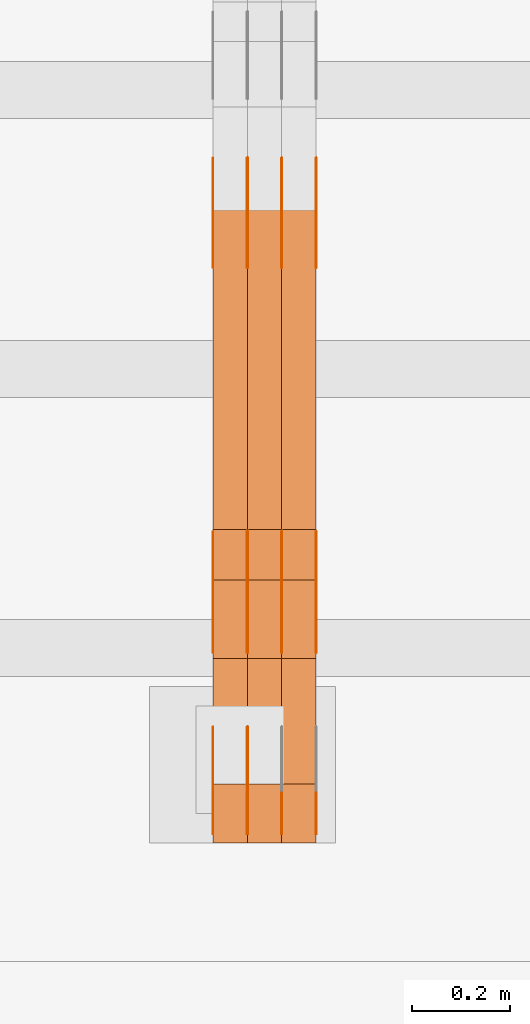
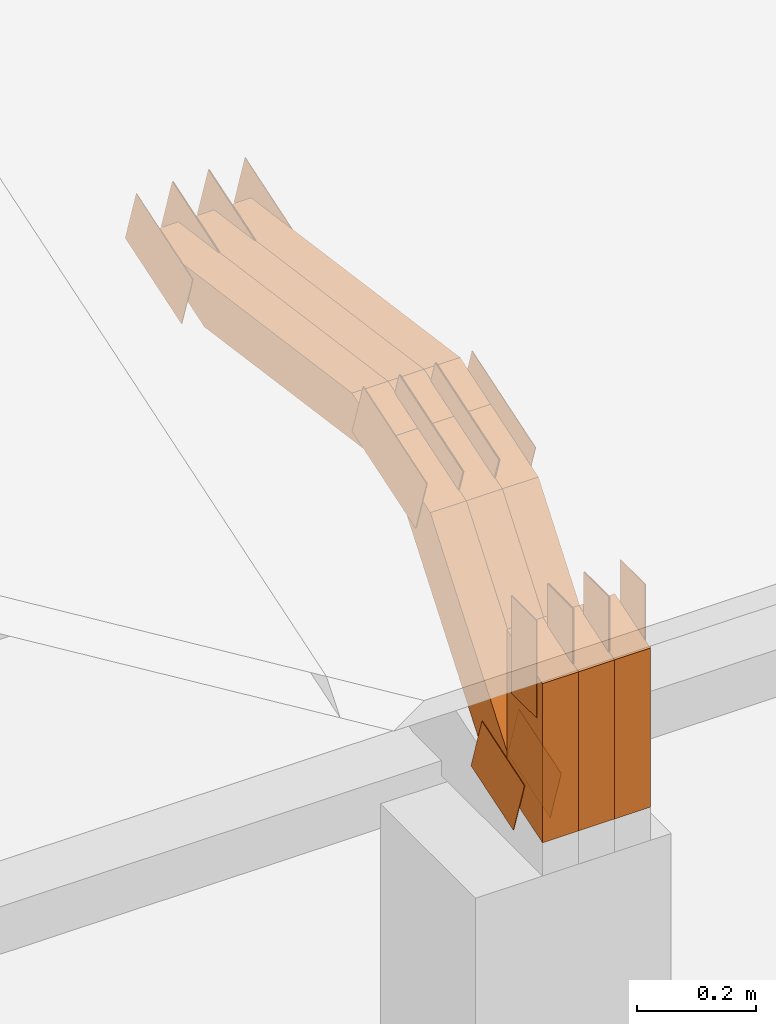
# One storey, part 267 of 385: 29 proxies.
"""IFC2X3 building model written with IfcOpenShell, lengths in millimetres."""

from ifc_helpers import new_model, entity, si_unit, converted_unit, derived_unit, direction, frame, frame_2d, origin, place, context, subcontext, project, spatial, polyline, rectangle, outline, extrude, source, transform, mapped, material, type_object, type_shapes, element, save


model = new_model("IFC2X3")

# Units and contexts
model_context = context("Model", 3, precision=0.01, world=origin(), true_north=direction((6.12303176911189e-17, 1.0)))
body_context = subcontext(model_context, "Body", "Model", "MODEL_VIEW")
ifc_project = project(units=[si_unit("LENGTHUNIT", "METRE", prefix="MILLI"), si_unit("AREAUNIT", "SQUARE_METRE"), si_unit("VOLUMEUNIT", "CUBIC_METRE"), converted_unit("PLANEANGLEUNIT", "DEGREE", entity("IfcRatioMeasure", 0.0174532925199433), si_unit("PLANEANGLEUNIT", "RADIAN"), dimensions=[0, 0, 0, 0, 0, 0, 0]), si_unit("MASSUNIT", "GRAM", prefix="KILO"), derived_unit("MASSDENSITYUNIT", [(si_unit("MASSUNIT", "GRAM", prefix="KILO"), 1), (si_unit("LENGTHUNIT", "METRE"), -3)]), si_unit("TIMEUNIT", "SECOND"), si_unit("FREQUENCYUNIT", "HERTZ"), si_unit("THERMODYNAMICTEMPERATUREUNIT", "DEGREE_CELSIUS"), derived_unit("THERMALTRANSMITTANCEUNIT", [(si_unit("MASSUNIT", "GRAM", prefix="KILO"), 1), (si_unit("THERMODYNAMICTEMPERATUREUNIT", "KELVIN"), -1), (si_unit("TIMEUNIT", "SECOND"), -3)]), derived_unit("VOLUMETRICFLOWRATEUNIT", [(si_unit("LENGTHUNIT", "METRE"), 3), (si_unit("TIMEUNIT", "SECOND"), -1)]), si_unit("ELECTRICCURRENTUNIT", "AMPERE"), si_unit("ELECTRICVOLTAGEUNIT", "VOLT"), si_unit("POWERUNIT", "WATT"), si_unit("FORCEUNIT", "NEWTON", prefix="KILO"), si_unit("ILLUMINANCEUNIT", "LUX"), si_unit("LUMINOUSFLUXUNIT", "LUMEN"), si_unit("LUMINOUSINTENSITYUNIT", "CANDELA"), derived_unit("USERDEFINED", [(si_unit("MASSUNIT", "GRAM", prefix="KILO"), -1), (si_unit("LENGTHUNIT", "METRE"), -2), (si_unit("TIMEUNIT", "SECOND"), 3), (si_unit("LUMINOUSFLUXUNIT", "LUMEN"), 1)]), derived_unit("LINEARVELOCITYUNIT", [(si_unit("LENGTHUNIT", "METRE"), 1), (si_unit("TIMEUNIT", "SECOND"), -1)]), si_unit("PRESSUREUNIT", "PASCAL"), derived_unit("USERDEFINED", [(si_unit("LENGTHUNIT", "METRE"), -2), (si_unit("MASSUNIT", "GRAM", prefix="KILO"), 1), (si_unit("TIMEUNIT", "SECOND"), -2)])], contexts=[model_context])

# Site, building, storey
site_placement = place(None, origin())
site = spatial("IfcSite", under=ifc_project, at=site_placement, CompositionType="ELEMENT")
building_placement = place(site_placement, origin())
building = spatial("IfcBuilding", under=site, at=building_placement, CompositionType="ELEMENT")
storey_placement = place(building_placement, origin())
storey = spatial("IfcBuildingStorey", under=building, at=storey_placement, Name="Default", CompositionType="ELEMENT", Elevation=0.0)

# Proxies
ifc_material_1 = material(Name="IfcSurfaceStyle #546392")
building_element_proxy_type_1 = type_object("IfcBuildingElementProxyType", PredefinedType="NOTDEFINED", material=ifc_material_1)
shared_shape_1 = source(origin(), body_context, "Body", "SweptSolid", [
    extrude(outline(polyline([(-74.999865408764, -60.0000379172698), (74.9998729365771, -60.0000379172698), (74.9998642299588, 60.0000379172698), (-74.9998717577719, 60.0000379172698), (-74.999865408764, -60.0000379172698)])), frame((75.0005044383734, 60.0001679035349, 0.0), z_axis=(0.0, 0.0, 1.0), x_axis=(-1.0, 0.0, 0.0)), (0.0, 0.0, 1.0), 1.29999999999999),
])
type_shapes(building_element_proxy_type_1, [shared_shape_1])
proxy_1_placement = place(building_placement, frame((45246.3, 2998.66143710398, 150.423871180894), z_axis=(-1.0, 0.0, 0.0), x_axis=(0.0, 0.951056516295124, 0.309016994375039)))
element("IfcBuildingElementProxy", 1, at=proxy_1_placement, inside=storey, type_object=building_element_proxy_type_1, material=ifc_material_1, context=body_context, shape_type="MappedRepresentation", body=[
    mapped(shared_shape_1, transform((0.0, 0.0, 0.0), scale=1.0)),
])
ifc_material_2 = material(Name="IfcSurfaceStyle #546335")
building_element_proxy_type_2 = type_object("IfcBuildingElementProxyType", PredefinedType="NOTDEFINED", material=ifc_material_2)
shared_shape_2 = source(origin(), body_context, "Body", "SweptSolid", [
    extrude(outline(polyline([(-74.999865408764, -60.0000379172698), (74.9998729365771, -60.0000379172698), (74.9998642299588, 60.0000379172698), (-74.9998717577719, 60.0000379172698), (-74.999865408764, -60.0000379172698)])), frame((75.0005044383734, 60.0001679035349, 0.0), z_axis=(0.0, 0.0, 1.0), x_axis=(-1.0, 0.0, 0.0)), (0.0, 0.0, 1.0), 1.29999999999999),
])
type_shapes(building_element_proxy_type_2, [shared_shape_2])
proxy_2_placement = place(building_placement, frame((45175.0, 2998.66143710398, 150.423871180894), z_axis=(-1.0, 0.0, 0.0), x_axis=(0.0, 0.951056516295124, 0.309016994375039)))
element("IfcBuildingElementProxy", 2, at=proxy_2_placement, inside=storey, type_object=building_element_proxy_type_2, material=ifc_material_2, context=body_context, shape_type="MappedRepresentation", body=[
    mapped(shared_shape_2, transform((0.0, 0.0, 0.0), scale=1.0)),
])
ifc_material_3 = material(Name="IfcSurfaceStyle #546278")
building_element_proxy_type_3 = type_object("IfcBuildingElementProxyType", PredefinedType="NOTDEFINED", material=ifc_material_3)
shared_shape_3 = source(origin(), body_context, "Body", "SweptSolid", [
    extrude(outline(polyline([(-99.9998204243802, -60.000067376167), (99.9998338462265, -60.000067376167), (99.9998204243802, 60.000067376167), (-99.9998338462265, 60.000067376167), (-99.9998204243802, -60.000067376167)])), frame((100.000602015329, 60.0001864986889, 0.0), z_axis=(0.0, 0.0, 1.0), x_axis=(-1.0, 0.0, 0.0)), (0.0, 0.0, 1.0), 1.3),
])
type_shapes(building_element_proxy_type_3, [shared_shape_3])
proxy_3_placement = place(building_placement, frame((45386.3, 4114.85465165113, 513.097031388771), z_axis=(-1.0, 0.0, 0.0), x_axis=(0.0, 0.951056516295124, 0.309016994375039)))
element("IfcBuildingElementProxy", 3, at=proxy_3_placement, inside=storey, type_object=building_element_proxy_type_3, material=ifc_material_3, context=body_context, shape_type="MappedRepresentation", body=[
    mapped(shared_shape_3, transform((0.0, 0.0, 0.0), scale=1.0)),
])
ifc_material_4 = material(Name="IfcSurfaceStyle #546221")
building_element_proxy_type_4 = type_object("IfcBuildingElementProxyType", PredefinedType="NOTDEFINED", material=ifc_material_4)
shared_shape_4 = source(origin(), body_context, "Body", "SweptSolid", [
    extrude(outline(polyline([(-99.9998204243802, -60.000067376167), (99.9998338462265, -60.000067376167), (99.9998204243802, 60.000067376167), (-99.9998338462265, 60.000067376167), (-99.9998204243802, -60.000067376167)])), frame((100.000602015329, 60.0001864986889, 0.0), z_axis=(0.0, 0.0, 1.0), x_axis=(-1.0, 0.0, 0.0)), (0.0, 0.0, 1.0), 1.3),
])
type_shapes(building_element_proxy_type_4, [shared_shape_4])
proxy_4_placement = place(building_placement, frame((45315.0, 4114.85465165113, 513.097031388771), z_axis=(-1.0, 0.0, 0.0), x_axis=(0.0, 0.951056516295124, 0.309016994375039)))
element("IfcBuildingElementProxy", 4, at=proxy_4_placement, inside=storey, type_object=building_element_proxy_type_4, material=ifc_material_4, context=body_context, shape_type="MappedRepresentation", body=[
    mapped(shared_shape_4, transform((0.0, 0.0, 0.0), scale=1.0)),
])
ifc_material_5 = material(Name="IfcSurfaceStyle #546164")
building_element_proxy_type_5 = type_object("IfcBuildingElementProxyType", PredefinedType="NOTDEFINED", material=ifc_material_5)
shared_shape_5 = source(origin(), body_context, "Body", "SweptSolid", [
    extrude(outline(polyline([(-99.9998204243802, -60.000067376167), (99.9998338462265, -60.000067376167), (99.9998204243802, 60.000067376167), (-99.9998338462265, 60.000067376167), (-99.9998204243802, -60.000067376167)])), frame((100.000602015329, 60.0001864986889, 0.0), z_axis=(0.0, 0.0, 1.0), x_axis=(-1.0, 0.0, 0.0)), (0.0, 0.0, 1.0), 1.3),
])
type_shapes(building_element_proxy_type_5, [shared_shape_5])
proxy_5_placement = place(building_placement, frame((45316.3, 4114.85465165113, 513.097031388771), z_axis=(-1.0, 0.0, 0.0), x_axis=(0.0, 0.951056516295124, 0.309016994375039)))
element("IfcBuildingElementProxy", 5, at=proxy_5_placement, inside=storey, type_object=building_element_proxy_type_5, material=ifc_material_5, context=body_context, shape_type="MappedRepresentation", body=[
    mapped(shared_shape_5, transform((0.0, 0.0, 0.0), scale=1.0)),
])
ifc_material_6 = material(Name="IfcSurfaceStyle #546107")
building_element_proxy_type_6 = type_object("IfcBuildingElementProxyType", PredefinedType="NOTDEFINED", material=ifc_material_6)
shared_shape_6 = source(origin(), body_context, "Body", "SweptSolid", [
    extrude(outline(polyline([(-99.9998204243802, -60.000067376167), (99.9998338462265, -60.000067376167), (99.9998204243802, 60.000067376167), (-99.9998338462265, 60.000067376167), (-99.9998204243802, -60.000067376167)])), frame((100.000602015329, 60.0001864986889, 0.0), z_axis=(0.0, 0.0, 1.0), x_axis=(-1.0, 0.0, 0.0)), (0.0, 0.0, 1.0), 1.29999999999998),
])
type_shapes(building_element_proxy_type_6, [shared_shape_6])
proxy_6_placement = place(building_placement, frame((45245.0, 4114.85465165113, 513.097031388771), z_axis=(-1.0, 0.0, 0.0), x_axis=(0.0, 0.951056516295124, 0.309016994375039)))
element("IfcBuildingElementProxy", 6, at=proxy_6_placement, inside=storey, type_object=building_element_proxy_type_6, material=ifc_material_6, context=body_context, shape_type="MappedRepresentation", body=[
    mapped(shared_shape_6, transform((0.0, 0.0, 0.0), scale=1.0)),
])
ifc_material_7 = material(Name="IfcSurfaceStyle #546050")
building_element_proxy_type_7 = type_object("IfcBuildingElementProxyType", PredefinedType="NOTDEFINED", material=ifc_material_7)
shared_shape_7 = source(origin(), body_context, "Body", "SweptSolid", [
    extrude(outline(polyline([(-99.9998204243802, -60.000067376167), (99.9998338462265, -60.000067376167), (99.9998204243802, 60.000067376167), (-99.9998338462265, 60.000067376167), (-99.9998204243802, -60.000067376167)])), frame((100.000602015329, 60.0001864986889, 0.0), z_axis=(0.0, 0.0, 1.0), x_axis=(-1.0, 0.0, 0.0)), (0.0, 0.0, 1.0), 1.29999999999998),
])
type_shapes(building_element_proxy_type_7, [shared_shape_7])
proxy_7_placement = place(building_placement, frame((45246.3, 4114.85465165113, 513.097031388771), z_axis=(-1.0, 0.0, 0.0), x_axis=(0.0, 0.951056516295124, 0.309016994375039)))
element("IfcBuildingElementProxy", 7, at=proxy_7_placement, inside=storey, type_object=building_element_proxy_type_7, material=ifc_material_7, context=body_context, shape_type="MappedRepresentation", body=[
    mapped(shared_shape_7, transform((0.0, 0.0, 0.0), scale=1.0)),
])
ifc_material_8 = material(Name="IfcSurfaceStyle #545993")
building_element_proxy_type_8 = type_object("IfcBuildingElementProxyType", PredefinedType="NOTDEFINED", material=ifc_material_8)
shared_shape_8 = source(origin(), body_context, "Body", "SweptSolid", [
    extrude(outline(polyline([(-99.9998204243802, -60.000067376167), (99.9998338462265, -60.000067376167), (99.9998204243802, 60.000067376167), (-99.9998338462265, 60.000067376167), (-99.9998204243802, -60.000067376167)])), frame((100.000602015329, 60.0001864986889, 0.0), z_axis=(0.0, 0.0, 1.0), x_axis=(-1.0, 0.0, 0.0)), (0.0, 0.0, 1.0), 1.29999999999999),
])
type_shapes(building_element_proxy_type_8, [shared_shape_8])
proxy_8_placement = place(building_placement, frame((45175.0, 4114.85465165113, 513.097031388771), z_axis=(-1.0, 0.0, 0.0), x_axis=(0.0, 0.951056516295124, 0.309016994375039)))
element("IfcBuildingElementProxy", 8, at=proxy_8_placement, inside=storey, type_object=building_element_proxy_type_8, material=ifc_material_8, context=body_context, shape_type="MappedRepresentation", body=[
    mapped(shared_shape_8, transform((0.0, 0.0, 0.0), scale=1.0)),
])
ifc_material_9 = material(Name="IfcSurfaceStyle #538070")
building_element_proxy_type_9 = type_object("IfcBuildingElementProxyType", PredefinedType="NOTDEFINED", material=ifc_material_9)
shared_shape_9 = source(origin(), body_context, "Body", "SweptSolid", [
    extrude(outline(polyline([(-112.500266735783, -59.9999130784581), (112.500275442392, -59.9999130784581), (112.500262020557, 59.9999130784582), (-112.500270727166, 59.9999130784581), (-112.500266735783, -59.9999130784581)])), frame((112.500275442392, 60.0001020984692, 0.0), z_axis=(0.0, 0.0, 1.0), x_axis=(-1.0, 0.0, 0.0)), (0.0, 0.0, 1.0), 1.3),
])
type_shapes(building_element_proxy_type_9, [shared_shape_9])
proxy_9_placement = place(building_placement, frame((45386.3, 3327.32420598509, 571.284602786019), z_axis=(-1.0, 0.0, 0.0), x_axis=(0.0, 0.951056516295154, 0.309016994374948)))
element("IfcBuildingElementProxy", 9, at=proxy_9_placement, inside=storey, type_object=building_element_proxy_type_9, material=ifc_material_9, context=body_context, shape_type="MappedRepresentation", body=[
    mapped(shared_shape_9, transform((0.0, 0.0, 0.0), scale=1.0)),
])
ifc_material_10 = material(Name="IfcSurfaceStyle #538013")
building_element_proxy_type_10 = type_object("IfcBuildingElementProxyType", PredefinedType="NOTDEFINED", material=ifc_material_10)
shared_shape_10 = source(origin(), body_context, "Body", "SweptSolid", [
    extrude(outline(polyline([(-112.500266735783, -59.9999130784581), (112.500275442392, -59.9999130784581), (112.500262020557, 59.9999130784582), (-112.500270727166, 59.9999130784581), (-112.500266735783, -59.9999130784581)])), frame((112.500275442392, 60.0001020984692, 0.0), z_axis=(0.0, 0.0, 1.0), x_axis=(-1.0, 0.0, 0.0)), (0.0, 0.0, 1.0), 1.3),
])
type_shapes(building_element_proxy_type_10, [shared_shape_10])
proxy_10_placement = place(building_placement, frame((45315.0, 3327.32420598509, 571.284602786019), z_axis=(-1.0, 0.0, 0.0), x_axis=(0.0, 0.951056516295154, 0.309016994374948)))
element("IfcBuildingElementProxy", 10, at=proxy_10_placement, inside=storey, type_object=building_element_proxy_type_10, material=ifc_material_10, context=body_context, shape_type="MappedRepresentation", body=[
    mapped(shared_shape_10, transform((0.0, 0.0, 0.0), scale=1.0)),
])
ifc_material_11 = material(Name="IfcSurfaceStyle #537956")
building_element_proxy_type_11 = type_object("IfcBuildingElementProxyType", PredefinedType="NOTDEFINED", material=ifc_material_11)
shared_shape_11 = source(origin(), body_context, "Body", "SweptSolid", [
    extrude(outline(polyline([(-112.500266735783, -59.9999130784581), (112.500275442392, -59.9999130784581), (112.500262020557, 59.9999130784582), (-112.500270727166, 59.9999130784581), (-112.500266735783, -59.9999130784581)])), frame((112.500275442392, 60.0001020984692, 0.0), z_axis=(0.0, 0.0, 1.0), x_axis=(-1.0, 0.0, 0.0)), (0.0, 0.0, 1.0), 1.3),
])
type_shapes(building_element_proxy_type_11, [shared_shape_11])
proxy_11_placement = place(building_placement, frame((45316.3, 3327.32420598509, 571.284602786019), z_axis=(-1.0, 0.0, 0.0), x_axis=(0.0, 0.951056516295154, 0.309016994374948)))
element("IfcBuildingElementProxy", 11, at=proxy_11_placement, inside=storey, type_object=building_element_proxy_type_11, material=ifc_material_11, context=body_context, shape_type="MappedRepresentation", body=[
    mapped(shared_shape_11, transform((0.0, 0.0, 0.0), scale=1.0)),
])
ifc_material_12 = material(Name="IfcSurfaceStyle #537899")
building_element_proxy_type_12 = type_object("IfcBuildingElementProxyType", PredefinedType="NOTDEFINED", material=ifc_material_12)
shared_shape_12 = source(origin(), body_context, "Body", "SweptSolid", [
    extrude(outline(polyline([(-112.500266735783, -59.9999130784581), (112.500275442392, -59.9999130784581), (112.500262020557, 59.9999130784582), (-112.500270727166, 59.9999130784581), (-112.500266735783, -59.9999130784581)])), frame((112.500275442392, 60.0001020984692, 0.0), z_axis=(0.0, 0.0, 1.0), x_axis=(-1.0, 0.0, 0.0)), (0.0, 0.0, 1.0), 1.29999999999998),
])
type_shapes(building_element_proxy_type_12, [shared_shape_12])
proxy_12_placement = place(building_placement, frame((45245.0, 3327.32420598509, 571.284602786019), z_axis=(-1.0, 0.0, 0.0), x_axis=(0.0, 0.951056516295154, 0.309016994374948)))
element("IfcBuildingElementProxy", 12, at=proxy_12_placement, inside=storey, type_object=building_element_proxy_type_12, material=ifc_material_12, context=body_context, shape_type="MappedRepresentation", body=[
    mapped(shared_shape_12, transform((0.0, 0.0, 0.0), scale=1.0)),
])
ifc_material_13 = material(Name="IfcSurfaceStyle #537842")
building_element_proxy_type_13 = type_object("IfcBuildingElementProxyType", PredefinedType="NOTDEFINED", material=ifc_material_13)
shared_shape_13 = source(origin(), body_context, "Body", "SweptSolid", [
    extrude(outline(polyline([(-112.500266735783, -59.9999130784581), (112.500275442392, -59.9999130784581), (112.500262020557, 59.9999130784582), (-112.500270727166, 59.9999130784581), (-112.500266735783, -59.9999130784581)])), frame((112.500275442392, 60.0001020984692, 0.0), z_axis=(0.0, 0.0, 1.0), x_axis=(-1.0, 0.0, 0.0)), (0.0, 0.0, 1.0), 1.29999999999998),
])
type_shapes(building_element_proxy_type_13, [shared_shape_13])
proxy_13_placement = place(building_placement, frame((45246.3, 3327.32420598509, 571.284602786019), z_axis=(-1.0, 0.0, 0.0), x_axis=(0.0, 0.951056516295154, 0.309016994374948)))
element("IfcBuildingElementProxy", 13, at=proxy_13_placement, inside=storey, type_object=building_element_proxy_type_13, material=ifc_material_13, context=body_context, shape_type="MappedRepresentation", body=[
    mapped(shared_shape_13, transform((0.0, 0.0, 0.0), scale=1.0)),
])
ifc_material_14 = material(Name="IfcSurfaceStyle #537785")
building_element_proxy_type_14 = type_object("IfcBuildingElementProxyType", PredefinedType="NOTDEFINED", material=ifc_material_14)
shared_shape_14 = source(origin(), body_context, "Body", "SweptSolid", [
    extrude(outline(polyline([(-112.500266735783, -59.9999130784581), (112.500275442392, -59.9999130784581), (112.500262020557, 59.9999130784582), (-112.500270727166, 59.9999130784581), (-112.500266735783, -59.9999130784581)])), frame((112.500275442392, 60.0001020984692, 0.0), z_axis=(0.0, 0.0, 1.0), x_axis=(-1.0, 0.0, 0.0)), (0.0, 0.0, 1.0), 1.29999999999999),
])
type_shapes(building_element_proxy_type_14, [shared_shape_14])
proxy_14_placement = place(building_placement, frame((45175.0, 3327.32420598509, 571.284602786019), z_axis=(-1.0, 0.0, 0.0), x_axis=(0.0, 0.951056516295154, 0.309016994374948)))
element("IfcBuildingElementProxy", 14, at=proxy_14_placement, inside=storey, type_object=building_element_proxy_type_14, material=ifc_material_14, context=body_context, shape_type="MappedRepresentation", body=[
    mapped(shared_shape_14, transform((0.0, 0.0, 0.0), scale=1.0)),
])
ifc_material_15 = material(Name="IfcSurfaceStyle #537044")
building_element_proxy_type_15 = type_object("IfcBuildingElementProxyType", PredefinedType="NOTDEFINED", material=ifc_material_15)
shared_shape_15 = source(origin(), body_context, "Body", "SweptSolid", [
    extrude(rectangle(XDim=199.999969482422, YDim=84.0, at=frame_2d((1.4210854715202e-14, 0.0), x_axis=(1.0, 0.0))), frame((100.000010815955, 42.0, 0.0), z_axis=(0.0, 0.0, 1.0), x_axis=(-1.0, 0.0, 0.0)), (0.0, 0.0, 1.0), 1.3),
])
type_shapes(building_element_proxy_type_15, [shared_shape_15])
proxy_15_placement = place(building_placement, frame((45386.3, 3042.0, 514.460048047401), z_axis=(-1.0, 0.0, 0.0), x_axis=(0.0, 0.0, -1.0)))
element("IfcBuildingElementProxy", 15, at=proxy_15_placement, inside=storey, type_object=building_element_proxy_type_15, material=ifc_material_15, context=body_context, shape_type="MappedRepresentation", body=[
    mapped(shared_shape_15, transform((0.0, 0.0, 0.0), scale=1.0)),
])
ifc_material_16 = material(Name="IfcSurfaceStyle #536987")
building_element_proxy_type_16 = type_object("IfcBuildingElementProxyType", PredefinedType="NOTDEFINED", material=ifc_material_16)
shared_shape_16 = source(origin(), body_context, "Body", "SweptSolid", [
    extrude(rectangle(XDim=199.999969482422, YDim=84.0, at=frame_2d((1.4210854715202e-14, 0.0), x_axis=(1.0, 0.0))), frame((100.000010815955, 42.0, 0.0), z_axis=(0.0, 0.0, 1.0), x_axis=(-1.0, 0.0, 0.0)), (0.0, 0.0, 1.0), 1.3),
])
type_shapes(building_element_proxy_type_16, [shared_shape_16])
proxy_16_placement = place(building_placement, frame((45315.0, 3042.0, 514.460048047401), z_axis=(-1.0, 0.0, 0.0), x_axis=(0.0, 0.0, -1.0)))
element("IfcBuildingElementProxy", 16, at=proxy_16_placement, inside=storey, type_object=building_element_proxy_type_16, material=ifc_material_16, context=body_context, shape_type="MappedRepresentation", body=[
    mapped(shared_shape_16, transform((0.0, 0.0, 0.0), scale=1.0)),
])
ifc_material_17 = material(Name="IfcSurfaceStyle #536930")
building_element_proxy_type_17 = type_object("IfcBuildingElementProxyType", PredefinedType="NOTDEFINED", material=ifc_material_17)
shared_shape_17 = source(origin(), body_context, "Body", "SweptSolid", [
    extrude(rectangle(XDim=199.999969482422, YDim=84.0, at=frame_2d((1.4210854715202e-14, 0.0), x_axis=(1.0, 0.0))), frame((100.000010815955, 42.0, 0.0), z_axis=(0.0, 0.0, 1.0), x_axis=(-1.0, 0.0, 0.0)), (0.0, 0.0, 1.0), 1.3),
])
type_shapes(building_element_proxy_type_17, [shared_shape_17])
proxy_17_placement = place(building_placement, frame((45316.3, 3042.0, 514.460048047401), z_axis=(-1.0, 0.0, 0.0), x_axis=(0.0, 0.0, -1.0)))
element("IfcBuildingElementProxy", 17, at=proxy_17_placement, inside=storey, type_object=building_element_proxy_type_17, material=ifc_material_17, context=body_context, shape_type="MappedRepresentation", body=[
    mapped(shared_shape_17, transform((0.0, 0.0, 0.0), scale=1.0)),
])
ifc_material_18 = material(Name="IfcSurfaceStyle #536873")
building_element_proxy_type_18 = type_object("IfcBuildingElementProxyType", PredefinedType="NOTDEFINED", material=ifc_material_18)
shared_shape_18 = source(origin(), body_context, "Body", "SweptSolid", [
    extrude(rectangle(XDim=199.999969482422, YDim=84.0, at=frame_2d((1.4210854715202e-14, 0.0), x_axis=(1.0, 0.0))), frame((100.000010815955, 42.0, 0.0), z_axis=(0.0, 0.0, 1.0), x_axis=(-1.0, 0.0, 0.0)), (0.0, 0.0, 1.0), 1.29999999999998),
])
type_shapes(building_element_proxy_type_18, [shared_shape_18])
proxy_18_placement = place(building_placement, frame((45245.0, 3042.0, 514.460048047401), z_axis=(-1.0, 0.0, 0.0), x_axis=(0.0, 0.0, -1.0)))
element("IfcBuildingElementProxy", 18, at=proxy_18_placement, inside=storey, type_object=building_element_proxy_type_18, material=ifc_material_18, context=body_context, shape_type="MappedRepresentation", body=[
    mapped(shared_shape_18, transform((0.0, 0.0, 0.0), scale=1.0)),
])
ifc_material_19 = material(Name="IfcSurfaceStyle #536816")
building_element_proxy_type_19 = type_object("IfcBuildingElementProxyType", PredefinedType="NOTDEFINED", material=ifc_material_19)
shared_shape_19 = source(origin(), body_context, "Body", "SweptSolid", [
    extrude(rectangle(XDim=199.999969482422, YDim=84.0, at=frame_2d((1.4210854715202e-14, 0.0), x_axis=(1.0, 0.0))), frame((100.000010815955, 42.0, 0.0), z_axis=(0.0, 0.0, 1.0), x_axis=(-1.0, 0.0, 0.0)), (0.0, 0.0, 1.0), 1.29999999999998),
])
type_shapes(building_element_proxy_type_19, [shared_shape_19])
proxy_19_placement = place(building_placement, frame((45246.3, 3042.0, 514.460048047401), z_axis=(-1.0, 0.0, 0.0), x_axis=(0.0, 0.0, -1.0)))
element("IfcBuildingElementProxy", 19, at=proxy_19_placement, inside=storey, type_object=building_element_proxy_type_19, material=ifc_material_19, context=body_context, shape_type="MappedRepresentation", body=[
    mapped(shared_shape_19, transform((0.0, 0.0, 0.0), scale=1.0)),
])
ifc_material_20 = material(Name="IfcSurfaceStyle #536759")
building_element_proxy_type_20 = type_object("IfcBuildingElementProxyType", PredefinedType="NOTDEFINED", material=ifc_material_20)
shared_shape_20 = source(origin(), body_context, "Body", "SweptSolid", [
    extrude(rectangle(XDim=199.999969482422, YDim=84.0, at=frame_2d((1.4210854715202e-14, 0.0), x_axis=(1.0, 0.0))), frame((100.000010815955, 42.0, 0.0), z_axis=(0.0, 0.0, 1.0), x_axis=(-1.0, 0.0, 0.0)), (0.0, 0.0, 1.0), 1.29999999999999),
])
type_shapes(building_element_proxy_type_20, [shared_shape_20])
proxy_20_placement = place(building_placement, frame((45175.0, 3042.0, 514.460048047401), z_axis=(-1.0, 0.0, 0.0), x_axis=(0.0, 0.0, -1.0)))
element("IfcBuildingElementProxy", 20, at=proxy_20_placement, inside=storey, type_object=building_element_proxy_type_20, material=ifc_material_20, context=body_context, shape_type="MappedRepresentation", body=[
    mapped(shared_shape_20, transform((0.0, 0.0, 0.0), scale=1.0)),
])
ifc_material_21 = material(Name="IfcSurfaceStyle #525776")
building_element_proxy_type_21 = type_object("IfcBuildingElementProxyType", Name="T1-W3 525774", PredefinedType="NOTDEFINED", material=ifc_material_21)
shared_shape_21 = source(origin(), body_context, "Body", "SweptSolid", [
    extrude(outline(polyline([(-314.232579911788, -47.5000200125938), (325.164873061766, -47.5000200125938), (297.999869081008, 6.48085173424295e-05), (200.434027234171, 47.4999876083351), (-509.366189465157, 47.4999876083352), (-314.232579911788, -47.5000200125938)])), frame((325.164873061766, 47.5001564752191, 0.0), z_axis=(0.0, 0.0, 1.0), x_axis=(-1.0, 0.0, 0.0)), (0.0, 0.0, 1.0), 70.0),
])
type_shapes(building_element_proxy_type_21, [shared_shape_21])
proxy_21_placement = place(building_placement, frame((45385.0, 3457.43747924876, 620.49890325051), z_axis=(-1.0, 0.0, 0.0), x_axis=(0.0, 0.990367219823621, -0.138465771578512)))
element("IfcBuildingElementProxy", 21, at=proxy_21_placement, inside=storey, type_object=building_element_proxy_type_21, material=ifc_material_21, Name="T1-W3", context=body_context, shape_type="MappedRepresentation", body=[
    mapped(shared_shape_21, transform((0.0, 0.0, 0.0), scale=1.0)),
])
ifc_material_22 = material(Name="IfcSurfaceStyle #525710")
building_element_proxy_type_22 = type_object("IfcBuildingElementProxyType", Name="T1-W3 525708", PredefinedType="NOTDEFINED", material=ifc_material_22)
shared_shape_22 = source(origin(), body_context, "Body", "SweptSolid", [
    extrude(outline(polyline([(-314.232579911788, -47.5000200125938), (325.164873061766, -47.5000200125938), (297.999869081008, 6.48085173424295e-05), (200.434027234171, 47.4999876083351), (-509.366189465157, 47.4999876083352), (-314.232579911788, -47.5000200125938)])), frame((325.164873061766, 47.5001564752191, 0.0), z_axis=(0.0, 0.0, 1.0), x_axis=(-1.0, 0.0, 0.0)), (0.0, 0.0, 1.0), 70.0),
])
type_shapes(building_element_proxy_type_22, [shared_shape_22])
proxy_22_placement = place(building_placement, frame((45315.0, 3457.43747924876, 620.49890325051), z_axis=(-1.0, 0.0, 0.0), x_axis=(0.0, 0.990367219823621, -0.138465771578512)))
element("IfcBuildingElementProxy", 22, at=proxy_22_placement, inside=storey, type_object=building_element_proxy_type_22, material=ifc_material_22, Name="T1-W3", context=body_context, shape_type="MappedRepresentation", body=[
    mapped(shared_shape_22, transform((0.0, 0.0, 0.0), scale=1.0)),
])
ifc_material_23 = material(Name="IfcSurfaceStyle #525644")
building_element_proxy_type_23 = type_object("IfcBuildingElementProxyType", Name="T1-W3 525642", PredefinedType="NOTDEFINED", material=ifc_material_23)
shared_shape_23 = source(origin(), body_context, "Body", "SweptSolid", [
    extrude(outline(polyline([(-314.232579911788, -47.5000200125938), (325.164873061766, -47.5000200125938), (297.999869081008, 6.48085173424295e-05), (200.434027234171, 47.4999876083351), (-509.366189465157, 47.4999876083352), (-314.232579911788, -47.5000200125938)])), frame((325.164873061766, 47.5001564752191, 0.0), z_axis=(0.0, 0.0, 1.0), x_axis=(-1.0, 0.0, 0.0)), (0.0, 0.0, 1.0), 70.0),
])
type_shapes(building_element_proxy_type_23, [shared_shape_23])
proxy_23_placement = place(building_placement, frame((45245.0, 3457.43747924876, 620.49890325051), z_axis=(-1.0, 0.0, 0.0), x_axis=(0.0, 0.990367219823621, -0.138465771578512)))
element("IfcBuildingElementProxy", 23, at=proxy_23_placement, inside=storey, type_object=building_element_proxy_type_23, material=ifc_material_23, Name="T1-W3", context=body_context, shape_type="MappedRepresentation", body=[
    mapped(shared_shape_23, transform((0.0, 0.0, 0.0), scale=1.0)),
])
ifc_material_24 = material(Name="IfcSurfaceStyle #525380")
building_element_proxy_type_24 = type_object("IfcBuildingElementProxyType", Name="T1-W14 525378", PredefinedType="NOTDEFINED", material=ifc_material_24)
shared_shape_24 = source(origin(), body_context, "Body", "SweptSolid", [
    extrude(outline(polyline([(-374.484689776928, -47.499919737532), (177.199556189275, -47.499919737532), (246.893257937645, -5.36774925340877e-05), (185.487930694801, 47.4999465762783), (-235.096055044793, 47.4999465762784), (-374.484689776928, -47.499919737532)])), frame((246.893257937645, 47.5000959779252, 0.0), z_axis=(0.0, 0.0, 1.0), x_axis=(-1.0, 0.0, 0.0)), (0.0, 0.0, 1.0), 70.0),
])
type_shapes(building_element_proxy_type_24, [shared_shape_24])
proxy_24_placement = place(building_placement, frame((45385.0, 3022.42877773025, 136.329406512195), z_axis=(-1.0, 0.0, 0.0), x_axis=(0.0, 0.611854146609475, 0.790970608352037)))
element("IfcBuildingElementProxy", 24, at=proxy_24_placement, inside=storey, type_object=building_element_proxy_type_24, material=ifc_material_24, Name="T1-W14", context=body_context, shape_type="MappedRepresentation", body=[
    mapped(shared_shape_24, transform((0.0, 0.0, 0.0), scale=1.0)),
])
ifc_material_25 = material(Name="IfcSurfaceStyle #525314")
building_element_proxy_type_25 = type_object("IfcBuildingElementProxyType", Name="T1-W14 525312", PredefinedType="NOTDEFINED", material=ifc_material_25)
shared_shape_25 = source(origin(), body_context, "Body", "SweptSolid", [
    extrude(outline(polyline([(-374.484689776928, -47.499919737532), (177.199556189275, -47.499919737532), (246.893257937645, -5.36774925340877e-05), (185.487930694801, 47.4999465762783), (-235.096055044793, 47.4999465762784), (-374.484689776928, -47.499919737532)])), frame((246.893257937645, 47.5000959779252, 0.0), z_axis=(0.0, 0.0, 1.0), x_axis=(-1.0, 0.0, 0.0)), (0.0, 0.0, 1.0), 70.0),
])
type_shapes(building_element_proxy_type_25, [shared_shape_25])
proxy_25_placement = place(building_placement, frame((45315.0, 3022.42877773025, 136.329406512195), z_axis=(-1.0, 0.0, 0.0), x_axis=(0.0, 0.611854146609475, 0.790970608352037)))
element("IfcBuildingElementProxy", 25, at=proxy_25_placement, inside=storey, type_object=building_element_proxy_type_25, material=ifc_material_25, Name="T1-W14", context=body_context, shape_type="MappedRepresentation", body=[
    mapped(shared_shape_25, transform((0.0, 0.0, 0.0), scale=1.0)),
])
ifc_material_26 = material(Name="IfcSurfaceStyle #525248")
building_element_proxy_type_26 = type_object("IfcBuildingElementProxyType", Name="T1-W14 525246", PredefinedType="NOTDEFINED", material=ifc_material_26)
shared_shape_26 = source(origin(), body_context, "Body", "SweptSolid", [
    extrude(outline(polyline([(-374.484689776928, -47.499919737532), (177.199556189275, -47.499919737532), (246.893257937645, -5.36774925340877e-05), (185.487930694801, 47.4999465762783), (-235.096055044793, 47.4999465762784), (-374.484689776928, -47.499919737532)])), frame((246.893257937645, 47.5000959779252, 0.0), z_axis=(0.0, 0.0, 1.0), x_axis=(-1.0, 0.0, 0.0)), (0.0, 0.0, 1.0), 70.0),
])
type_shapes(building_element_proxy_type_26, [shared_shape_26])
proxy_26_placement = place(building_placement, frame((45245.0, 3022.42877773025, 136.329406512195), z_axis=(-1.0, 0.0, 0.0), x_axis=(0.0, 0.611854146609475, 0.790970608352037)))
element("IfcBuildingElementProxy", 26, at=proxy_26_placement, inside=storey, type_object=building_element_proxy_type_26, material=ifc_material_26, Name="T1-W14", context=body_context, shape_type="MappedRepresentation", body=[
    mapped(shared_shape_26, transform((0.0, 0.0, 0.0), scale=1.0)),
])
ifc_material_27 = material(Name="IfcSurfaceStyle #525182")
building_element_proxy_type_27 = type_object("IfcBuildingElementProxyType", Name="T1-E3 525180", PredefinedType="NOTDEFINED", material=ifc_material_27)
shared_shape_27 = source(origin(), body_context, "Body", "SweptSolid", [
    extrude(outline(polyline([(-182.839673995971, -60.0), (143.849313735962, -60.0), (182.839677810669, 60.0), (-143.84931755066, 60.0), (-182.839673995971, -60.0)])), frame((182.839677810669, 60.0, 0.0), z_axis=(0.0, 0.0, 1.0), x_axis=(-1.0, 0.0, 0.0)), (0.0, 0.0, 1.0), 70.0),
])
type_shapes(building_element_proxy_type_27, [shared_shape_27])
proxy_27_placement = place(building_placement, frame((45385.0, 2940.0, 68.27587890625), z_axis=(-1.0, 0.0, 0.0), x_axis=(0.0, 0.0, 1.0)))
element("IfcBuildingElementProxy", 27, at=proxy_27_placement, inside=storey, type_object=building_element_proxy_type_27, material=ifc_material_27, Name="T1-E3", context=body_context, shape_type="MappedRepresentation", body=[
    mapped(shared_shape_27, transform((0.0, 0.0, 0.0), scale=1.0)),
])
ifc_material_28 = material(Name="IfcSurfaceStyle #525125")
building_element_proxy_type_28 = type_object("IfcBuildingElementProxyType", Name="T1-E3 525123", PredefinedType="NOTDEFINED", material=ifc_material_28)
shared_shape_28 = source(origin(), body_context, "Body", "SweptSolid", [
    extrude(outline(polyline([(-182.839673995971, -60.0), (143.849313735962, -60.0), (182.839677810669, 60.0), (-143.84931755066, 60.0), (-182.839673995971, -60.0)])), frame((182.839677810669, 60.0, 0.0), z_axis=(0.0, 0.0, 1.0), x_axis=(-1.0, 0.0, 0.0)), (0.0, 0.0, 1.0), 70.0),
])
type_shapes(building_element_proxy_type_28, [shared_shape_28])
proxy_28_placement = place(building_placement, frame((45315.0, 2940.0, 68.27587890625), z_axis=(-1.0, 0.0, 0.0), x_axis=(0.0, 0.0, 1.0)))
element("IfcBuildingElementProxy", 28, at=proxy_28_placement, inside=storey, type_object=building_element_proxy_type_28, material=ifc_material_28, Name="T1-E3", context=body_context, shape_type="MappedRepresentation", body=[
    mapped(shared_shape_28, transform((0.0, 0.0, 0.0), scale=1.0)),
])
ifc_material_29 = material(Name="IfcSurfaceStyle #525068")
building_element_proxy_type_29 = type_object("IfcBuildingElementProxyType", Name="T1-E3 525066", PredefinedType="NOTDEFINED", material=ifc_material_29)
shared_shape_29 = source(origin(), body_context, "Body", "SweptSolid", [
    extrude(outline(polyline([(-182.839673995971, -60.0), (143.849313735962, -60.0), (182.839677810669, 60.0), (-143.84931755066, 60.0), (-182.839673995971, -60.0)])), frame((182.839677810669, 60.0, 0.0), z_axis=(0.0, 0.0, 1.0), x_axis=(-1.0, 0.0, 0.0)), (0.0, 0.0, 1.0), 70.0),
])
type_shapes(building_element_proxy_type_29, [shared_shape_29])
proxy_29_placement = place(building_placement, frame((45245.0, 2940.0, 68.27587890625), z_axis=(-1.0, 0.0, 0.0), x_axis=(0.0, 0.0, 1.0)))
element("IfcBuildingElementProxy", 29, at=proxy_29_placement, inside=storey, type_object=building_element_proxy_type_29, material=ifc_material_29, Name="T1-E3", context=body_context, shape_type="MappedRepresentation", body=[
    mapped(shared_shape_29, transform((0.0, 0.0, 0.0), scale=1.0)),
])

save(model, "model.ifc")
